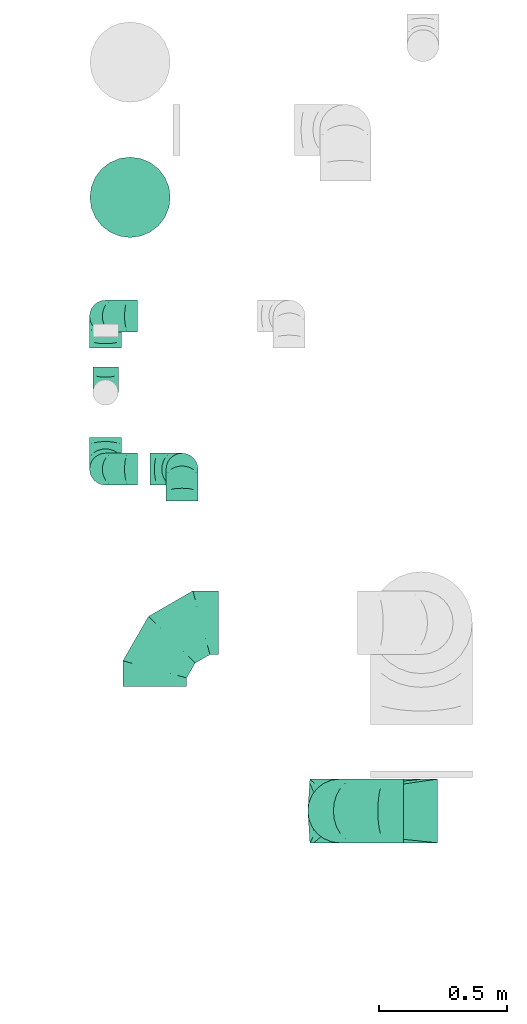
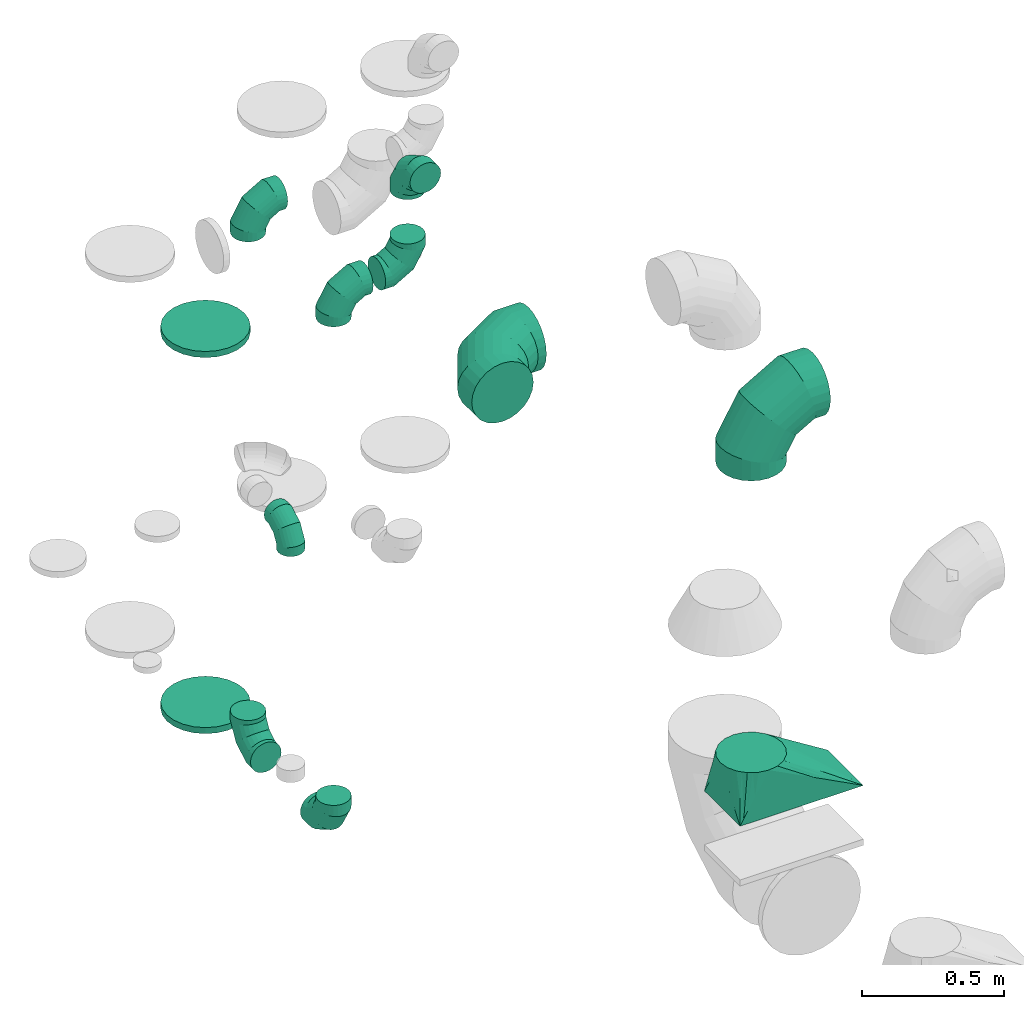
# One storey, part 44 of 59: 12 flow fittings.
"""IFC2X3 building model written with IfcOpenShell, lengths in millimetres."""

from ifc_helpers import new_model, entity, si_unit, converted_unit, derived_unit, direction, frame, origin, place, context, subcontext, project, spatial, faceted_brep, source, transform, mapped, material, type_object, type_shapes, element, save


model = new_model("IFC2X3")

# Units and contexts
model_context = context("Model", 3, precision=0.01, world=origin(), true_north=direction((6.12303176911189e-17, 1.0)))
body_context = subcontext(model_context, "Body", "Model", "MODEL_VIEW")
ifc_project = project(units=[si_unit("LENGTHUNIT", "METRE", prefix="MILLI"), si_unit("AREAUNIT", "SQUARE_METRE"), si_unit("VOLUMEUNIT", "CUBIC_METRE"), converted_unit("PLANEANGLEUNIT", "DEGREE", entity("IfcRatioMeasure", 0.0174532925199433), si_unit("PLANEANGLEUNIT", "RADIAN"), dimensions=[0, 0, 0, 0, 0, 0, 0]), si_unit("MASSUNIT", "GRAM", prefix="KILO"), derived_unit("MASSDENSITYUNIT", [(si_unit("MASSUNIT", "GRAM", prefix="KILO"), 1), (si_unit("LENGTHUNIT", "METRE"), -3)]), derived_unit("MOMENTOFINERTIAUNIT", [(si_unit("LENGTHUNIT", "METRE"), 4)]), si_unit("TIMEUNIT", "SECOND"), si_unit("FREQUENCYUNIT", "HERTZ"), si_unit("THERMODYNAMICTEMPERATUREUNIT", "DEGREE_CELSIUS"), derived_unit("THERMALTRANSMITTANCEUNIT", [(si_unit("MASSUNIT", "GRAM", prefix="KILO"), 1), (si_unit("THERMODYNAMICTEMPERATUREUNIT", "KELVIN"), -1), (si_unit("TIMEUNIT", "SECOND"), -3)]), derived_unit("VOLUMETRICFLOWRATEUNIT", [(si_unit("LENGTHUNIT", "METRE"), 3), (si_unit("TIMEUNIT", "SECOND"), -1)]), derived_unit("MASSFLOWRATEUNIT", [(si_unit("MASSUNIT", "GRAM", prefix="KILO"), 1), (si_unit("TIMEUNIT", "SECOND"), -1)]), derived_unit("ROTATIONALFREQUENCYUNIT", [(si_unit("TIMEUNIT", "SECOND"), -1)]), si_unit("ELECTRICCURRENTUNIT", "AMPERE"), si_unit("ELECTRICVOLTAGEUNIT", "VOLT"), si_unit("POWERUNIT", "WATT"), si_unit("FORCEUNIT", "NEWTON", prefix="KILO"), si_unit("ILLUMINANCEUNIT", "LUX"), si_unit("LUMINOUSFLUXUNIT", "LUMEN"), si_unit("LUMINOUSINTENSITYUNIT", "CANDELA"), derived_unit("USERDEFINED", [(si_unit("MASSUNIT", "GRAM", prefix="KILO"), -1), (si_unit("LENGTHUNIT", "METRE"), -2), (si_unit("TIMEUNIT", "SECOND"), 3), (si_unit("LUMINOUSFLUXUNIT", "LUMEN"), 1)]), derived_unit("LINEARVELOCITYUNIT", [(si_unit("LENGTHUNIT", "METRE"), 1), (si_unit("TIMEUNIT", "SECOND"), -1)]), si_unit("PRESSUREUNIT", "PASCAL"), derived_unit("USERDEFINED", [(si_unit("LENGTHUNIT", "METRE"), -2), (si_unit("MASSUNIT", "GRAM", prefix="KILO"), 1), (si_unit("TIMEUNIT", "SECOND"), -2)]), derived_unit("LINEARFORCEUNIT", [(si_unit("MASSUNIT", "GRAM", prefix="KILO"), 1), (si_unit("LENGTHUNIT", "METRE"), 1), (si_unit("TIMEUNIT", "SECOND"), -2), (si_unit("LENGTHUNIT", "METRE"), -1)]), derived_unit("PLANARFORCEUNIT", [(si_unit("MASSUNIT", "GRAM", prefix="KILO"), 1), (si_unit("LENGTHUNIT", "METRE"), 1), (si_unit("TIMEUNIT", "SECOND"), -2), (si_unit("LENGTHUNIT", "METRE"), -2)])], contexts=[model_context])

# Site, building, storey
site_placement = place(None, origin())
site = spatial("IfcSite", under=ifc_project, at=site_placement, CompositionType="ELEMENT")
building_placement = place(site_placement, origin())
building = spatial("IfcBuilding", under=site, at=building_placement, CompositionType="ELEMENT")
storey_placement = place(building_placement, frame((0.0, 0.0, 28200.0)))
storey = spatial("IfcBuildingStorey", under=building, at=storey_placement, CompositionType="ELEMENT", Elevation=28200.0)

# Flow fittings
ifc_material = material()
duct_fitting_type_1 = type_object("IfcDuctFittingType", PredefinedType="NOTDEFINED", material=ifc_material)
shared_shape_1 = source(origin(), body_context, "Body", "Brep", [
    faceted_brep([(-100.0, 0.0, -50.0), (-100.0, -12.94, -48.3), (-100.0, -25.0, -43.3), (-100.0, -35.36, -35.36), (-100.0, -43.3, -25.0), (-100.0, -48.3, -12.94), (-100.0, -50.0, 0.0), (-100.0, -48.3, 12.94), (-100.0, -43.3, 25.0), (-100.0, -35.36, 35.36), (-100.0, -25.0, 43.3), (-100.0, -12.94, 48.3), (-100.0, 0.0, 50.0), (-100.0, 12.94, 48.3), (-100.0, 25.0, 43.3), (-100.0, 35.36, 35.36), (-100.0, 43.3, 25.0), (-100.0, 48.3, 12.94), (-100.0, 50.0, 0.0), (-100.0, 48.3, -12.94), (-100.0, 43.3, -25.0), (-100.0, 35.36, -35.36), (-100.0, 25.0, -43.3), (-100.0, 12.94, -48.3), (-76.67, 12.94, 48.3), (-79.9, 25.0, 43.3), (-73.21, 0.0, 50.0), (-82.68, 35.36, 35.36), (-86.15, 48.3, 12.94), (-86.6, 50.0, 0.0), (-84.81, 43.3, 25.0), (-84.81, 43.3, -25.0), (-82.68, 35.36, -35.36), (-86.15, 48.3, -12.94), (-76.67, 12.94, -48.3), (-73.21, 0.0, -50.0), (-79.9, 25.0, -43.3), (-69.74, -12.94, -48.3), (-66.51, -25.0, -43.3), (-63.73, -35.36, -35.36), (-61.6, -43.3, -25.0), (-60.26, -48.3, -12.94), (-59.81, -50.0, 0.0), (-60.26, -48.3, 12.94), (-61.6, -43.3, 25.0), (-63.73, -35.36, 35.36), (-66.51, -25.0, 43.3), (-69.74, -12.94, 48.3), (-36.27, 36.27, 48.3), (-45.1, 45.1, 43.3), (-26.79, 26.79, 50.0), (-52.68, 52.68, 35.36), (-58.49, 58.49, 25.0), (-62.15, 62.15, 12.94), (-63.4, 63.4, 0.0), (-62.15, 62.15, -12.94), (-58.49, 58.49, -25.0), (-52.68, 52.68, -35.36), (-36.27, 36.27, -48.3), (-26.79, 26.79, -50.0), (-45.1, 45.1, -43.3), (-17.32, 17.32, -48.3), (-8.49, 8.49, -43.3), (-0.91, 0.91, -35.36), (4.9, -4.9, -25.0), (8.56, -8.56, -12.94), (9.81, -9.81, 0.0), (8.56, -8.56, 12.94), (4.9, -4.9, 25.0), (-0.91, 0.91, 35.36), (-8.49, 8.49, 43.3), (-17.32, 17.32, 48.3), (-12.94, 76.67, 48.3), (-25.0, 79.9, 43.3), (0.0, 73.21, 50.0), (-35.36, 82.68, 35.36), (-43.3, 84.81, 25.0), (-48.3, 86.15, 12.94), (-50.0, 86.6, 0.0), (-48.3, 86.15, -12.94), (-43.3, 84.81, -25.0), (-35.36, 82.68, -35.36), (-12.94, 76.67, -48.3), (0.0, 73.21, -50.0), (-25.0, 79.9, -43.3), (12.94, 69.74, -48.3), (25.0, 66.51, -43.3), (35.36, 63.73, -35.36), (43.3, 61.6, -25.0), (48.3, 60.26, -12.94), (50.0, 59.81, 0.0), (48.3, 60.26, 12.94), (43.3, 61.6, 25.0), (35.36, 63.73, 35.36), (25.0, 66.51, 43.3), (12.94, 69.74, 48.3), (-12.94, 100.0, -48.3), (-25.0, 100.0, -43.3), (-35.36, 100.0, -35.36), (-43.3, 100.0, -25.0), (-48.3, 100.0, -12.94), (-50.0, 100.0, 0.0), (-48.3, 100.0, 12.94), (-43.3, 100.0, 25.0), (-35.36, 100.0, 35.36), (-25.0, 100.0, 43.3), (-12.94, 100.0, 48.3), (0.0, 100.0, 50.0), (12.94, 100.0, 48.3), (25.0, 100.0, 43.3), (35.36, 100.0, 35.36), (43.3, 100.0, 25.0), (48.3, 100.0, 12.94), (50.0, 100.0, 0.0), (48.3, 100.0, -12.94), (43.3, 100.0, -25.0), (35.36, 100.0, -35.36), (25.0, 100.0, -43.3), (12.94, 100.0, -48.3), (0.0, 100.0, -50.0)], [[[0, 1, 2, 3, 4, 5, 6, 7, 8, 9, 10, 11, 12, 13, 14, 15, 16, 17, 18, 19, 20, 21, 22, 23]], [[24, 25, 14, 13]], [[26, 24, 13, 12]], [[14, 25, 27, 15]], [[28, 29, 18, 17]], [[30, 28, 17, 16]], [[15, 27, 30, 16]], [[20, 31, 32, 21]], [[33, 31, 20, 19]], [[18, 29, 33, 19]], [[34, 35, 0, 23]], [[36, 34, 23, 22]], [[32, 36, 22, 21]], [[2, 1, 37, 38]], [[3, 2, 38, 39]], [[0, 35, 37, 1]], [[5, 4, 40, 41]], [[6, 5, 41, 42]], [[3, 39, 40, 4]], [[6, 42, 43, 7]], [[7, 43, 44, 8]], [[8, 44, 45, 9]], [[10, 46, 47, 11]], [[11, 47, 26, 12]], [[10, 9, 45, 46]], [[48, 49, 25, 24]], [[50, 48, 24, 26]], [[27, 25, 49, 51]], [[52, 53, 28, 30]], [[51, 52, 30, 27]], [[29, 28, 53, 54]], [[55, 56, 31, 33]], [[54, 55, 33, 29]], [[57, 32, 31, 56]], [[58, 59, 35, 34]], [[60, 58, 34, 36]], [[57, 60, 36, 32]], [[37, 35, 59, 61]], [[38, 37, 61, 62]], [[39, 38, 62, 63]], [[41, 40, 64, 65]], [[42, 41, 65, 66]], [[63, 64, 40, 39]], [[43, 42, 66, 67]], [[44, 43, 67, 68]], [[68, 69, 45, 44]], [[46, 45, 69, 70]], [[47, 46, 70, 71]], [[26, 47, 71, 50]], [[72, 73, 49, 48]], [[74, 72, 48, 50]], [[51, 49, 73, 75]], [[76, 77, 53, 52]], [[75, 76, 52, 51]], [[54, 53, 77, 78]], [[79, 80, 56, 55]], [[78, 79, 55, 54]], [[81, 57, 56, 80]], [[82, 83, 59, 58]], [[84, 82, 58, 60]], [[81, 84, 60, 57]], [[61, 59, 83, 85]], [[62, 61, 85, 86]], [[63, 62, 86, 87]], [[65, 64, 88, 89]], [[66, 65, 89, 90]], [[87, 88, 64, 63]], [[67, 66, 90, 91]], [[68, 67, 91, 92]], [[92, 93, 69, 68]], [[70, 69, 93, 94]], [[71, 70, 94, 95]], [[50, 71, 95, 74]], [[96, 97, 98, 99, 100, 101, 102, 103, 104, 105, 106, 107, 108, 109, 110, 111, 112, 113, 114, 115, 116, 117, 118, 119]], [[72, 74, 107, 106]], [[73, 72, 106, 105]], [[75, 73, 105, 104]], [[77, 76, 103, 102]], [[78, 77, 102, 101]], [[75, 104, 103, 76]], [[78, 101, 100, 79]], [[79, 100, 99, 80]], [[80, 99, 98, 81]], [[96, 119, 83, 82]], [[97, 96, 82, 84]], [[84, 81, 98, 97]], [[83, 119, 118, 85]], [[85, 118, 117, 86]], [[86, 117, 116, 87]], [[88, 115, 114, 89]], [[89, 114, 113, 90]], [[87, 116, 115, 88]], [[91, 90, 113, 112]], [[92, 91, 112, 111]], [[93, 92, 111, 110]], [[95, 94, 109, 108]], [[74, 95, 108, 107]], [[110, 109, 94, 93]]]),
])
type_shapes(duct_fitting_type_1, [shared_shape_1])
flow_fitting_1_placement = place(storey_placement, frame((71473.8, 14848.58, 1800.0), z_axis=(-1.0, 0.0, 0.0), x_axis=(0.0, 0.0, 1.0)))
element("IfcFlowFitting", 1, at=flow_fitting_1_placement, inside=storey, type_object=duct_fitting_type_1, material=ifc_material, context=body_context, shape_type="MappedRepresentation", body=[
    mapped(shared_shape_1, transform((0.0, 0.0, 0.0), scale=1.0)),
])
duct_fitting_type_2 = type_object("IfcDuctFittingType", PredefinedType="NOTDEFINED", material=ifc_material)
shared_shape_2 = source(origin(), body_context, "Body", "Brep", [
    faceted_brep([(-250.0, 0.0, -125.0), (-250.0, -32.35, -120.74), (-250.0, -62.5, -108.25), (-250.0, -88.39, -88.39), (-250.0, -108.25, -62.5), (-250.0, -120.74, -32.35), (-250.0, -125.0, 0.0), (-250.0, -120.74, 32.35), (-250.0, -108.25, 62.5), (-250.0, -88.39, 88.39), (-250.0, -62.5, 108.25), (-250.0, -32.35, 120.74), (-250.0, 0.0, 125.0), (-250.0, 32.35, 120.74), (-250.0, 62.5, 108.25), (-250.0, 88.39, 88.39), (-250.0, 108.25, 62.5), (-250.0, 120.74, 32.35), (-250.0, 125.0, 0.0), (-250.0, 120.74, -32.35), (-250.0, 108.25, -62.5), (-250.0, 88.39, -88.39), (-250.0, 62.5, -108.25), (-250.0, 32.35, -120.74), (-191.68, 32.35, 120.74), (-199.76, 62.5, 108.25), (-183.01, 0.0, 125.0), (-206.7, 88.39, 88.39), (-215.37, 120.74, 32.35), (-216.51, 125.0, 0.0), (-212.02, 108.25, 62.5), (-212.02, 108.25, -62.5), (-206.7, 88.39, -88.39), (-215.37, 120.74, -32.35), (-191.68, 32.35, -120.74), (-183.01, 0.0, -125.0), (-199.76, 62.5, -108.25), (-174.34, -32.35, -120.74), (-166.27, -62.5, -108.25), (-159.33, -88.39, -88.39), (-154.01, -108.25, -62.5), (-150.66, -120.74, -32.35), (-149.52, -125.0, 0.0), (-150.66, -120.74, 32.35), (-154.01, -108.25, 62.5), (-159.33, -88.39, 88.39), (-166.27, -62.5, 108.25), (-174.34, -32.35, 120.74), (-90.67, 90.67, 120.74), (-112.74, 112.74, 108.25), (-66.99, 66.99, 125.0), (-131.69, 131.69, 88.39), (-146.23, 146.23, 62.5), (-155.38, 155.38, 32.35), (-158.49, 158.49, 0.0), (-155.38, 155.38, -32.35), (-146.23, 146.23, -62.5), (-131.69, 131.69, -88.39), (-90.67, 90.67, -120.74), (-66.99, 66.99, -125.0), (-112.74, 112.74, -108.25), (-43.3, 43.3, -120.74), (-21.23, 21.23, -108.25), (-2.28, 2.28, -88.39), (12.26, -12.26, -62.5), (21.4, -21.4, -32.35), (24.52, -24.52, 0.0), (21.4, -21.4, 32.35), (12.26, -12.26, 62.5), (-2.28, 2.28, 88.39), (-21.23, 21.23, 108.25), (-43.3, 43.3, 120.74), (-32.35, 191.68, 120.74), (-62.5, 199.76, 108.25), (0.0, 183.01, 125.0), (-88.39, 206.7, 88.39), (-108.25, 212.02, 62.5), (-120.74, 215.37, 32.35), (-125.0, 216.51, 0.0), (-120.74, 215.37, -32.35), (-108.25, 212.02, -62.5), (-88.39, 206.7, -88.39), (-32.35, 191.68, -120.74), (0.0, 183.01, -125.0), (-62.5, 199.76, -108.25), (32.35, 174.34, -120.74), (62.5, 166.27, -108.25), (88.39, 159.33, -88.39), (108.25, 154.01, -62.5), (120.74, 150.66, -32.35), (125.0, 149.52, 0.0), (120.74, 150.66, 32.35), (108.25, 154.01, 62.5), (88.39, 159.33, 88.39), (62.5, 166.27, 108.25), (32.35, 174.34, 120.74), (-32.35, 250.0, -120.74), (-62.5, 250.0, -108.25), (-88.39, 250.0, -88.39), (-108.25, 250.0, -62.5), (-120.74, 250.0, -32.35), (-125.0, 250.0, 0.0), (-120.74, 250.0, 32.35), (-108.25, 250.0, 62.5), (-88.39, 250.0, 88.39), (-62.5, 250.0, 108.25), (-32.35, 250.0, 120.74), (0.0, 250.0, 125.0), (32.35, 250.0, 120.74), (62.5, 250.0, 108.25), (88.39, 250.0, 88.39), (108.25, 250.0, 62.5), (120.74, 250.0, 32.35), (125.0, 250.0, 0.0), (120.74, 250.0, -32.35), (108.25, 250.0, -62.5), (88.39, 250.0, -88.39), (62.5, 250.0, -108.25), (32.35, 250.0, -120.74), (0.0, 250.0, -125.0)], [[[0, 1, 2, 3, 4, 5, 6, 7, 8, 9, 10, 11, 12, 13, 14, 15, 16, 17, 18, 19, 20, 21, 22, 23]], [[24, 25, 14, 13]], [[26, 24, 13, 12]], [[14, 25, 27, 15]], [[28, 29, 18, 17]], [[30, 28, 17, 16]], [[15, 27, 30, 16]], [[20, 31, 32, 21]], [[33, 31, 20, 19]], [[18, 29, 33, 19]], [[34, 35, 0, 23]], [[36, 34, 23, 22]], [[21, 32, 36, 22]], [[1, 0, 35, 37]], [[2, 1, 37, 38]], [[38, 39, 3, 2]], [[5, 4, 40, 41]], [[6, 5, 41, 42]], [[39, 40, 4, 3]], [[6, 42, 43, 7]], [[7, 43, 44, 8]], [[8, 44, 45, 9]], [[9, 45, 46, 10]], [[10, 46, 47, 11]], [[26, 12, 11, 47]], [[48, 49, 25, 24]], [[50, 48, 24, 26]], [[27, 25, 49, 51]], [[52, 53, 28, 30]], [[51, 52, 30, 27]], [[29, 28, 53, 54]], [[55, 56, 31, 33]], [[54, 55, 33, 29]], [[32, 31, 56, 57]], [[58, 59, 35, 34]], [[60, 58, 34, 36]], [[57, 60, 36, 32]], [[37, 35, 59, 61]], [[38, 37, 61, 62]], [[39, 38, 62, 63]], [[41, 40, 64, 65]], [[42, 41, 65, 66]], [[63, 64, 40, 39]], [[43, 42, 66, 67]], [[44, 43, 67, 68]], [[68, 69, 45, 44]], [[46, 45, 69, 70]], [[47, 46, 70, 71]], [[26, 47, 71, 50]], [[72, 73, 49, 48]], [[74, 72, 48, 50]], [[51, 49, 73, 75]], [[76, 77, 53, 52]], [[75, 76, 52, 51]], [[54, 53, 77, 78]], [[79, 80, 56, 55]], [[78, 79, 55, 54]], [[57, 56, 80, 81]], [[82, 83, 59, 58]], [[84, 82, 58, 60]], [[81, 84, 60, 57]], [[61, 59, 83, 85]], [[62, 61, 85, 86]], [[63, 62, 86, 87]], [[65, 64, 88, 89]], [[66, 65, 89, 90]], [[87, 88, 64, 63]], [[67, 66, 90, 91]], [[68, 67, 91, 92]], [[92, 93, 69, 68]], [[70, 69, 93, 94]], [[71, 70, 94, 95]], [[50, 71, 95, 74]], [[96, 97, 98, 99, 100, 101, 102, 103, 104, 105, 106, 107, 108, 109, 110, 111, 112, 113, 114, 115, 116, 117, 118, 119]], [[72, 74, 107, 106]], [[73, 72, 106, 105]], [[75, 73, 105, 104]], [[77, 76, 103, 102]], [[78, 77, 102, 101]], [[75, 104, 103, 76]], [[78, 101, 100, 79]], [[79, 100, 99, 80]], [[80, 99, 98, 81]], [[84, 97, 96, 82]], [[82, 96, 119, 83]], [[84, 81, 98, 97]], [[83, 119, 118, 85]], [[85, 118, 117, 86]], [[116, 87, 86, 117]], [[88, 115, 114, 89]], [[89, 114, 113, 90]], [[115, 88, 87, 116]], [[91, 90, 113, 112]], [[92, 91, 112, 111]], [[111, 110, 93, 92]], [[95, 94, 109, 108]], [[74, 95, 108, 107]], [[110, 109, 94, 93]]]),
])
type_shapes(duct_fitting_type_2, [shared_shape_2])
for number, where, z_axis, x_axis in (
    (2, (71666.81, 13945.86, 3000.0), (0.0, 0.0, 1.0), (-1.0, 0.0, 0.0)),
    (3, (72391.81, 13207.7, 3000.0), (0.0, -1.0, 0.0), (-1.0, 0.0, 0.0)),
):
    element("IfcFlowFitting", number, at=place(storey_placement, frame(where, z_axis=z_axis, x_axis=x_axis)), inside=storey, type_object=duct_fitting_type_2, material=ifc_material, context=body_context, shape_type="MappedRepresentation", body=[
        mapped(shared_shape_2, transform((0.0, 0.0, 0.0), scale=1.0)),
    ])
duct_fitting_type_3 = type_object("IfcDuctFittingType", PredefinedType="NOTDEFINED", material=ifc_material)
shared_shape_3 = source(origin(), body_context, "Body", "Brep", [
    faceted_brep([(-125.0, 0.0, -62.5), (-125.0, -16.18, -60.37), (-125.0, -31.25, -54.13), (-125.0, -44.19, -44.19), (-125.0, -54.13, -31.25), (-125.0, -60.37, -16.18), (-125.0, -62.5, 0.0), (-125.0, -60.37, 16.18), (-125.0, -54.13, 31.25), (-125.0, -44.19, 44.19), (-125.0, -31.25, 54.13), (-125.0, -16.18, 60.37), (-125.0, 0.0, 62.5), (-125.0, 16.18, 60.37), (-125.0, 31.25, 54.13), (-125.0, 44.19, 44.19), (-125.0, 54.13, 31.25), (-125.0, 60.37, 16.18), (-125.0, 62.5, 0.0), (-125.0, 60.37, -16.18), (-125.0, 54.13, -31.25), (-125.0, 44.19, -44.19), (-125.0, 31.25, -54.13), (-125.0, 16.18, -60.37), (-95.84, 16.18, 60.37), (-99.88, 31.25, 54.13), (-91.51, 0.0, 62.5), (-103.35, 44.19, 44.19), (-107.68, 60.37, 16.18), (-108.25, 62.5, 0.0), (-106.01, 54.13, 31.25), (-106.01, 54.13, -31.25), (-103.35, 44.19, -44.19), (-107.68, 60.37, -16.18), (-95.84, 16.18, -60.37), (-91.51, 0.0, -62.5), (-99.88, 31.25, -54.13), (-87.17, -16.18, -60.37), (-83.13, -31.25, -54.13), (-79.66, -44.19, -44.19), (-77.0, -54.13, -31.25), (-75.33, -60.37, -16.18), (-74.76, -62.5, 0.0), (-75.33, -60.37, 16.18), (-77.0, -54.13, 31.25), (-79.66, -44.19, 44.19), (-83.13, -31.25, 54.13), (-87.17, -16.18, 60.37), (-45.34, 45.34, 60.37), (-56.37, 56.37, 54.13), (-33.49, 33.49, 62.5), (-65.85, 65.85, 44.19), (-73.12, 73.12, 31.25), (-77.69, 77.69, 16.18), (-79.25, 79.25, 0.0), (-77.69, 77.69, -16.18), (-73.12, 73.12, -31.25), (-65.85, 65.85, -44.19), (-45.34, 45.34, -60.37), (-33.49, 33.49, -62.5), (-56.37, 56.37, -54.13), (-21.65, 21.65, -60.37), (-10.62, 10.62, -54.13), (-1.14, 1.14, -44.19), (6.13, -6.13, -31.25), (10.7, -10.7, -16.18), (12.26, -12.26, 0.0), (10.7, -10.7, 16.18), (6.13, -6.13, 31.25), (-1.14, 1.14, 44.19), (-10.62, 10.62, 54.13), (-21.65, 21.65, 60.37), (-16.18, 95.84, 60.37), (-31.25, 99.88, 54.13), (0.0, 91.51, 62.5), (-44.19, 103.35, 44.19), (-54.13, 106.01, 31.25), (-60.37, 107.68, 16.18), (-62.5, 108.25, 0.0), (-60.37, 107.68, -16.18), (-54.13, 106.01, -31.25), (-44.19, 103.35, -44.19), (-16.18, 95.84, -60.37), (0.0, 91.51, -62.5), (-31.25, 99.88, -54.13), (16.18, 87.17, -60.37), (31.25, 83.13, -54.13), (44.19, 79.66, -44.19), (54.13, 77.0, -31.25), (60.37, 75.33, -16.18), (62.5, 74.76, 0.0), (60.37, 75.33, 16.18), (54.13, 77.0, 31.25), (44.19, 79.66, 44.19), (31.25, 83.13, 54.13), (16.18, 87.17, 60.37), (-16.18, 125.0, -60.37), (-31.25, 125.0, -54.13), (-44.19, 125.0, -44.19), (-54.13, 125.0, -31.25), (-60.37, 125.0, -16.18), (-62.5, 125.0, 0.0), (-60.37, 125.0, 16.18), (-54.13, 125.0, 31.25), (-44.19, 125.0, 44.19), (-31.25, 125.0, 54.13), (-16.18, 125.0, 60.37), (0.0, 125.0, 62.5), (16.18, 125.0, 60.37), (31.25, 125.0, 54.13), (44.19, 125.0, 44.19), (54.13, 125.0, 31.25), (60.37, 125.0, 16.18), (62.5, 125.0, 0.0), (60.37, 125.0, -16.18), (54.13, 125.0, -31.25), (44.19, 125.0, -44.19), (31.25, 125.0, -54.13), (16.18, 125.0, -60.37), (0.0, 125.0, -62.5)], [[[0, 1, 2, 3, 4, 5, 6, 7, 8, 9, 10, 11, 12, 13, 14, 15, 16, 17, 18, 19, 20, 21, 22, 23]], [[24, 25, 14, 13]], [[26, 24, 13, 12]], [[14, 25, 27, 15]], [[28, 29, 18, 17]], [[30, 28, 17, 16]], [[15, 27, 30, 16]], [[20, 31, 32, 21]], [[33, 31, 20, 19]], [[18, 29, 33, 19]], [[34, 35, 0, 23]], [[36, 34, 23, 22]], [[21, 32, 36, 22]], [[1, 0, 35, 37]], [[2, 1, 37, 38]], [[38, 39, 3, 2]], [[5, 4, 40, 41]], [[6, 5, 41, 42]], [[39, 40, 4, 3]], [[6, 42, 43, 7]], [[7, 43, 44, 8]], [[45, 9, 8, 44]], [[9, 45, 46, 10]], [[10, 46, 47, 11]], [[26, 12, 11, 47]], [[48, 49, 25, 24]], [[50, 48, 24, 26]], [[27, 25, 49, 51]], [[52, 53, 28, 30]], [[51, 52, 30, 27]], [[29, 28, 53, 54]], [[55, 56, 31, 33]], [[54, 55, 33, 29]], [[57, 32, 31, 56]], [[58, 59, 35, 34]], [[60, 58, 34, 36]], [[57, 60, 36, 32]], [[37, 35, 59, 61]], [[38, 37, 61, 62]], [[39, 38, 62, 63]], [[41, 40, 64, 65]], [[42, 41, 65, 66]], [[63, 64, 40, 39]], [[43, 42, 66, 67]], [[44, 43, 67, 68]], [[68, 69, 45, 44]], [[46, 45, 69, 70]], [[47, 46, 70, 71]], [[26, 47, 71, 50]], [[72, 73, 49, 48]], [[74, 72, 48, 50]], [[51, 49, 73, 75]], [[76, 77, 53, 52]], [[75, 76, 52, 51]], [[54, 53, 77, 78]], [[79, 80, 56, 55]], [[78, 79, 55, 54]], [[81, 57, 56, 80]], [[82, 83, 59, 58]], [[84, 82, 58, 60]], [[81, 84, 60, 57]], [[61, 59, 83, 85]], [[62, 61, 85, 86]], [[63, 62, 86, 87]], [[65, 64, 88, 89]], [[66, 65, 89, 90]], [[87, 88, 64, 63]], [[67, 66, 90, 91]], [[68, 67, 91, 92]], [[92, 93, 69, 68]], [[70, 69, 93, 94]], [[71, 70, 94, 95]], [[50, 71, 95, 74]], [[96, 97, 98, 99, 100, 101, 102, 103, 104, 105, 106, 107, 108, 109, 110, 111, 112, 113, 114, 115, 116, 117, 118, 119]], [[72, 74, 107, 106]], [[73, 72, 106, 105]], [[75, 73, 105, 104]], [[77, 76, 103, 102]], [[78, 77, 102, 101]], [[75, 104, 103, 76]], [[78, 101, 100, 79]], [[79, 100, 99, 80]], [[80, 99, 98, 81]], [[96, 119, 83, 82]], [[97, 96, 82, 84]], [[84, 81, 98, 97]], [[83, 119, 118, 85]], [[85, 118, 117, 86]], [[116, 87, 86, 117]], [[88, 115, 114, 89]], [[89, 114, 113, 90]], [[115, 88, 87, 116]], [[91, 90, 113, 112]], [[92, 91, 112, 111]], [[111, 110, 93, 92]], [[95, 94, 109, 108]], [[74, 95, 108, 107]], [[110, 109, 94, 93]]]),
])
type_shapes(duct_fitting_type_3, [shared_shape_3])
for number, where, z_axis, x_axis in (
    (4, (71473.8, 15147.75, 3000.0), (0.0, -1.0, 0.0), (-1.0, 0.0, 0.0)),
    (5, (71473.8, 15147.75, 700.0), (-1.0, 0.0, 0.0), (0.0, 0.0, -1.0)),
    (6, (71473.8, 14547.75, 700.0), (-1.0, 0.0, 0.0), (0.0, -1.0, 0.0)),
    (7, (71473.8, 14547.75, 3000.0), (0.0, 1.0, 0.0), (0.0, 0.0, 1.0)),
    (8, (71773.8, 14547.75, 3000.0), (0.0, -1.0, 0.0), (1.0, 0.0, 0.0)),
    (9, (71773.8, 14547.75, 3440.0), (1.0, 0.0, 0.0), (0.0, 0.0, 1.0)),
):
    element("IfcFlowFitting", number, at=place(storey_placement, frame(where, z_axis=z_axis, x_axis=x_axis)), inside=storey, type_object=duct_fitting_type_3, material=ifc_material, context=body_context, shape_type="MappedRepresentation", body=[
        mapped(shared_shape_3, transform((0.0, 0.0, 0.0), scale=1.0)),
    ])
duct_fitting_type_4 = type_object("IfcDuctFittingType", PredefinedType="NOTDEFINED", material=ifc_material)
shared_shape_4 = source(origin(), body_context, "Body", "Brep", [
    faceted_brep([(20.0, 0.0, -157.5), (20.0, 40.76, -152.13), (20.0, 78.75, -136.4), (20.0, 111.37, -111.37), (20.0, 136.4, -78.75), (20.0, 152.13, -40.76), (20.0, 157.5, 0.0), (20.0, 152.13, 40.76), (20.0, 136.4, 78.75), (20.0, 111.37, 111.37), (20.0, 78.75, 136.4), (20.0, 40.76, 152.13), (20.0, 0.0, 157.5), (20.0, -40.76, 152.13), (20.0, -78.75, 136.4), (20.0, -111.37, 111.37), (20.0, -136.4, 78.75), (20.0, -152.13, 40.76), (20.0, -157.5, 0.0), (20.0, -152.13, -40.76), (20.0, -136.4, -78.75), (20.0, -111.37, -111.37), (20.0, -78.75, -136.4), (20.0, -40.76, -152.13), (0.0, 0.0, 157.5), (-6.1, 0.0, 157.5), (-6.1, -40.76, 152.13), (0.0, -40.76, 152.13), (-6.1, -78.75, 136.4), (0.0, -78.75, 136.4), (0.0, -111.37, 111.37), (-6.1, -111.37, 111.37), (0.0, -136.4, 78.75), (-6.1, -136.4, 78.75), (-6.1, -152.13, 40.76), (0.0, -152.13, 40.76), (-6.1, -157.5, 0.0), (0.0, -157.5, 0.0), (-6.1, -152.13, -40.76), (0.0, -152.13, -40.76), (-6.1, -136.4, -78.75), (0.0, -136.4, -78.75), (0.0, -111.37, -111.37), (-6.1, -111.37, -111.37), (0.0, 0.0, -157.5), (0.0, -40.76, -152.13), (-6.1, -40.76, -152.13), (-6.1, 0.0, -157.5), (0.0, -78.75, -136.4), (-6.1, -78.75, -136.4), (-6.1, 40.76, -152.13), (0.0, 40.76, -152.13), (-6.1, 78.75, -136.4), (0.0, 78.75, -136.4), (0.0, 111.37, -111.37), (-6.1, 111.37, -111.37), (0.0, 136.4, -78.75), (-6.1, 136.4, -78.75), (-6.1, 152.13, -40.76), (0.0, 152.13, -40.76), (-6.1, 157.5, 0.0), (0.0, 157.5, 0.0), (-6.1, 152.13, 40.76), (0.0, 152.13, 40.76), (-6.1, 136.4, 78.75), (0.0, 136.4, 78.75), (0.0, 111.37, 111.37), (-6.1, 111.37, 111.37), (0.0, 78.75, 136.4), (-6.1, 78.75, 136.4), (-6.1, 40.76, 152.13), (0.0, 40.76, 152.13)], [[[0, 1, 2, 3, 4, 5, 6, 7, 8, 9, 10, 11, 12, 13, 14, 15, 16, 17, 18, 19, 20, 21, 22, 23]], [[13, 12, 24, 25, 26, 27]], [[14, 13, 27, 26, 28, 29]], [[30, 15, 14, 29, 28, 31]], [[17, 16, 32, 33, 34, 35]], [[18, 17, 35, 34, 36, 37]], [[32, 16, 15, 30, 31, 33]], [[19, 18, 37, 36, 38, 39]], [[20, 19, 39, 38, 40, 41]], [[42, 21, 20, 41, 40, 43]], [[44, 0, 23, 45, 46, 47]], [[48, 49, 46, 45, 23, 22]], [[22, 21, 42, 43, 49, 48]], [[1, 0, 44, 47, 50, 51]], [[2, 1, 51, 50, 52, 53]], [[54, 3, 2, 53, 52, 55]], [[5, 4, 56, 57, 58, 59]], [[6, 5, 59, 58, 60, 61]], [[56, 4, 3, 54, 55, 57]], [[7, 6, 61, 60, 62, 63]], [[8, 7, 63, 62, 64, 65]], [[66, 9, 8, 65, 64, 67]], [[11, 10, 68, 69, 70, 71]], [[12, 11, 71, 70, 25, 24]], [[68, 10, 9, 66, 67, 69]], [[46, 49, 43, 40, 38, 36, 34, 33, 31, 28, 26, 25, 70, 69, 67, 64, 62, 60, 58, 57, 55, 52, 50, 47]]]),
])
type_shapes(duct_fitting_type_4, [shared_shape_4])
for number, where, z_axis, x_axis in (
    (10, (71570.11, 15613.42, 525.0), (0.0, -1.0, 0.0), (0.0, 0.0, 1.0)),
    (11, (71570.11, 15613.42, 2150.0), (0.0, -1.0, 0.0), (0.0, 0.0, -1.0)),
):
    element("IfcFlowFitting", number, at=place(storey_placement, frame(where, z_axis=z_axis, x_axis=x_axis)), inside=storey, type_object=duct_fitting_type_4, material=ifc_material, context=body_context, shape_type="MappedRepresentation", body=[
        mapped(shared_shape_4, transform((0.0, 0.0, 0.0), scale=1.0)),
    ])
duct_fitting_type_5 = type_object("IfcDuctFittingType", PredefinedType="NOTDEFINED", material=ifc_material)
shared_shape_5 = source(origin(), body_context, "Body", "Brep", [
    faceted_brep([(200.0, -73.47, -234.29), (200.0, -56.05, -243.17), (200.0, -38.63, -252.04), (200.0, -23.84, -254.38), (200.0, -11.92, -256.27), (200.0, -5.96, -257.22), (200.0, 0.0, -258.16), (200.0, 5.96, -257.22), (200.0, 11.92, -256.27), (200.0, 23.84, -254.38), (200.0, 38.63, -252.04), (200.0, 56.05, -243.17), (200.0, 73.47, -234.29), (200.0, 87.3, -220.46), (200.0, 101.13, -206.63), (200.0, 110.0, -189.21), (200.0, 118.88, -171.79), (200.0, 121.22, -157.0), (200.0, 123.11, -145.08), (200.0, 124.06, -139.12), (200.0, 125.0, -133.16), (200.0, 124.06, -127.2), (200.0, 123.11, -121.24), (200.0, 121.22, -109.32), (200.0, 118.88, -94.53), (200.0, 110.0, -77.11), (200.0, 101.13, -59.69), (200.0, 87.3, -45.86), (200.0, 73.47, -32.03), (200.0, 56.05, -23.16), (200.0, 38.63, -14.28), (200.0, 23.84, -11.94), (200.0, 11.92, -10.05), (200.0, 5.96, -9.1), (200.0, 0.0, -8.16), (200.0, -5.96, -9.1), (200.0, -11.92, -10.05), (200.0, -23.84, -11.94), (200.0, -38.63, -14.28), (200.0, -56.05, -23.16), (200.0, -73.47, -32.03), (200.0, -87.3, -45.86), (200.0, -101.13, -59.69), (200.0, -110.0, -77.11), (200.0, -118.88, -94.53), (200.0, -121.22, -109.32), (200.0, -123.11, -121.24), (200.0, -124.06, -127.2), (200.0, -125.0, -133.16), (200.0, -124.06, -139.12), (200.0, -123.11, -145.08), (200.0, -121.22, -157.0), (200.0, -118.88, -171.79), (200.0, -110.0, -189.21), (200.0, -101.13, -206.63), (200.0, -87.3, -220.46), (0.0, -125.0, 250.0), (0.0, 125.0, 250.0), (0.0, 125.0, -250.0), (0.0, -125.0, -250.0), (104.11, -59.93, 115.61), (100.0, -103.94, 105.21), (26.03, -108.73, 216.4), (78.09, -76.2, 149.21), (52.06, -92.46, 182.8), (188.01, -7.49, 7.31), (176.03, -14.98, 22.78), (152.06, -29.96, 53.72), (128.09, -44.95, 84.67), (52.06, -125.0, 150.27), (78.09, -125.0, 100.4), (104.11, -125.0, 50.54), (128.09, -125.0, 4.61), (152.06, -125.0, -41.31), (176.03, -125.0, -87.24), (188.01, -125.0, -110.2), (26.03, -125.0, 200.13), (26.03, -125.0, -234.79), (52.06, -125.0, -219.59), (78.09, -125.0, -204.38), (104.11, -125.0, -189.18), (128.09, -125.0, -175.17), (152.06, -125.0, -161.17), (176.03, -125.0, -147.16), (188.01, -125.0, -140.16), (100.0, -109.29, -233.02), (52.06, -92.46, -252.12), (78.09, -76.2, -253.19), (104.11, -59.93, -254.25), (128.09, -44.95, -255.23), (152.06, -29.96, -256.2), (176.03, -14.98, -257.18), (188.01, -7.49, -257.67), (26.03, -108.73, -251.06), (26.03, 108.73, -251.06), (52.06, 92.46, -252.12), (78.09, 76.2, -253.19), (104.11, 59.93, -254.25), (128.09, 44.95, -255.23), (152.06, 29.96, -256.2), (176.03, 14.98, -257.18), (188.01, 7.49, -257.67), (100.0, 103.94, -238.37), (52.06, 125.0, -219.59), (78.09, 125.0, -204.38), (104.11, 125.0, -189.18), (128.09, 125.0, -175.17), (152.06, 125.0, -161.17), (176.03, 125.0, -147.16), (188.01, 125.0, -140.16), (26.03, 125.0, -234.79), (26.03, 125.0, 200.13), (52.06, 125.0, 150.27), (78.09, 125.0, 100.4), (104.11, 125.0, 50.54), (128.09, 125.0, 4.61), (152.06, 125.0, -41.31), (176.03, 125.0, -87.24), (188.01, 125.0, -110.2), (100.0, 109.29, 99.86), (52.06, 92.46, 182.8), (78.09, 76.2, 149.21), (104.11, 59.93, 115.61), (128.09, 44.95, 84.67), (152.06, 29.96, 53.72), (176.03, 14.98, 22.78), (188.01, 7.49, 7.31), (26.03, 108.73, 216.4)], [[[0, 1, 2, 3, 4, 5, 6, 7, 8, 9, 10, 11, 12, 13, 14, 15, 16, 17, 18, 19, 20, 21, 22, 23, 24, 25, 26, 27, 28, 29, 30, 31, 32, 33, 34, 35, 36, 37, 38, 39, 40, 41, 42, 43, 44, 45, 46, 47, 48, 49, 50, 51, 52, 53, 54, 55]], [[56, 57, 58, 59]], [[60, 39, 38]], [[56, 61, 62]], [[39, 60, 63, 64]], [[65, 66, 67, 68, 60, 38, 37, 36, 35, 34]], [[62, 61, 40]], [[43, 69, 70, 71]], [[64, 40, 39]], [[44, 71, 72, 73, 74, 75, 48, 47, 46, 45]], [[42, 76, 69]], [[71, 44, 43]], [[61, 76, 41]], [[40, 64, 62]], [[76, 42, 41]], [[40, 61, 41]], [[61, 56, 76]], [[69, 43, 42]], [[75, 74, 73, 72, 71, 70, 69, 76, 56, 59, 77, 78, 79, 80, 81, 82, 83, 84, 48]], [[80, 53, 52]], [[59, 85, 77]], [[53, 80, 79, 78]], [[84, 83, 82, 81, 80, 52, 51, 50, 49, 48]], [[77, 85, 54]], [[1, 86, 87, 88]], [[78, 54, 53]], [[2, 88, 89, 90, 91, 92, 6, 5, 4, 3]], [[0, 93, 86]], [[88, 2, 1]], [[85, 93, 55]], [[54, 78, 77]], [[93, 0, 55]], [[54, 85, 55]], [[85, 59, 93]], [[86, 1, 0]], [[92, 91, 90, 89, 88, 87, 86, 93, 59, 58, 94, 95, 96, 97, 98, 99, 100, 101, 6]], [[97, 11, 10]], [[58, 102, 94]], [[11, 97, 96, 95]], [[101, 100, 99, 98, 97, 10, 9, 8, 7, 6]], [[94, 102, 12]], [[15, 103, 104, 105]], [[95, 12, 11]], [[16, 105, 106, 107, 108, 109, 20, 19, 18, 17]], [[14, 110, 103]], [[105, 16, 15]], [[102, 110, 13]], [[12, 95, 94]], [[110, 14, 13]], [[12, 102, 13]], [[102, 58, 110]], [[103, 15, 14]], [[58, 57, 111, 112, 113, 114, 115, 116, 117, 118, 20, 109, 108, 107, 106, 105, 104, 103, 110]], [[114, 25, 24]], [[57, 119, 111]], [[25, 114, 113, 112]], [[118, 117, 116, 115, 114, 24, 23, 22, 21, 20]], [[111, 119, 26]], [[29, 120, 121, 122]], [[112, 26, 25]], [[30, 122, 123, 124, 125, 126, 34, 33, 32, 31]], [[28, 127, 120]], [[122, 30, 29]], [[119, 127, 27]], [[26, 112, 111]], [[127, 28, 27]], [[26, 119, 27]], [[119, 57, 127]], [[120, 29, 28]], [[57, 56, 62, 64, 63, 60, 68, 67, 66, 65, 34, 126, 125, 124, 123, 122, 121, 120, 127]]]),
])
type_shapes(duct_fitting_type_5, [shared_shape_5])
flow_fitting_2_placement = place(storey_placement, frame((72524.97, 13207.7, 1300.0), z_axis=(1.0, 0.0, 0.0), x_axis=(0.0, 0.0, 1.0)))
element("IfcFlowFitting", 12, at=flow_fitting_2_placement, inside=storey, type_object=duct_fitting_type_5, material=ifc_material, context=body_context, shape_type="MappedRepresentation", body=[
    mapped(shared_shape_5, transform((0.0, 0.0, 0.0), scale=1.0)),
])

save(model, "model.ifc")
